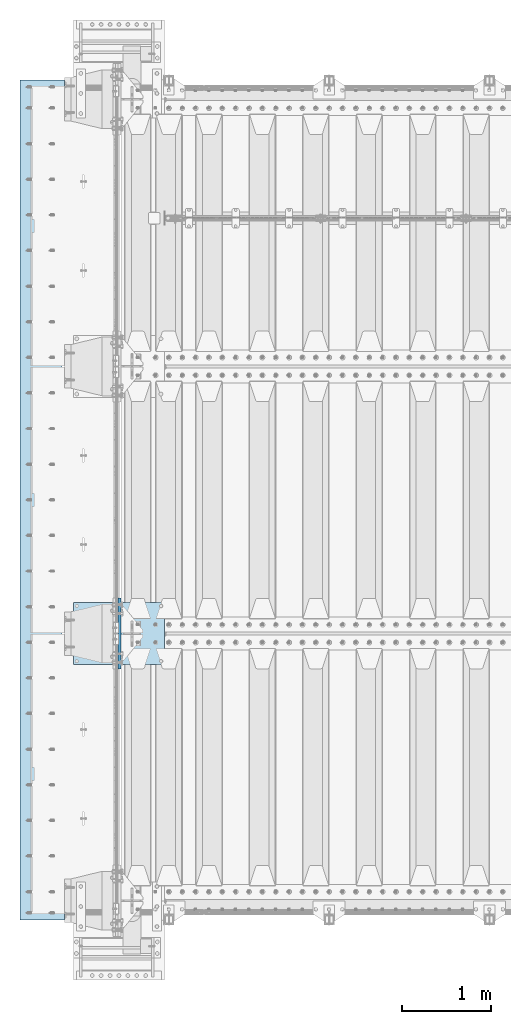
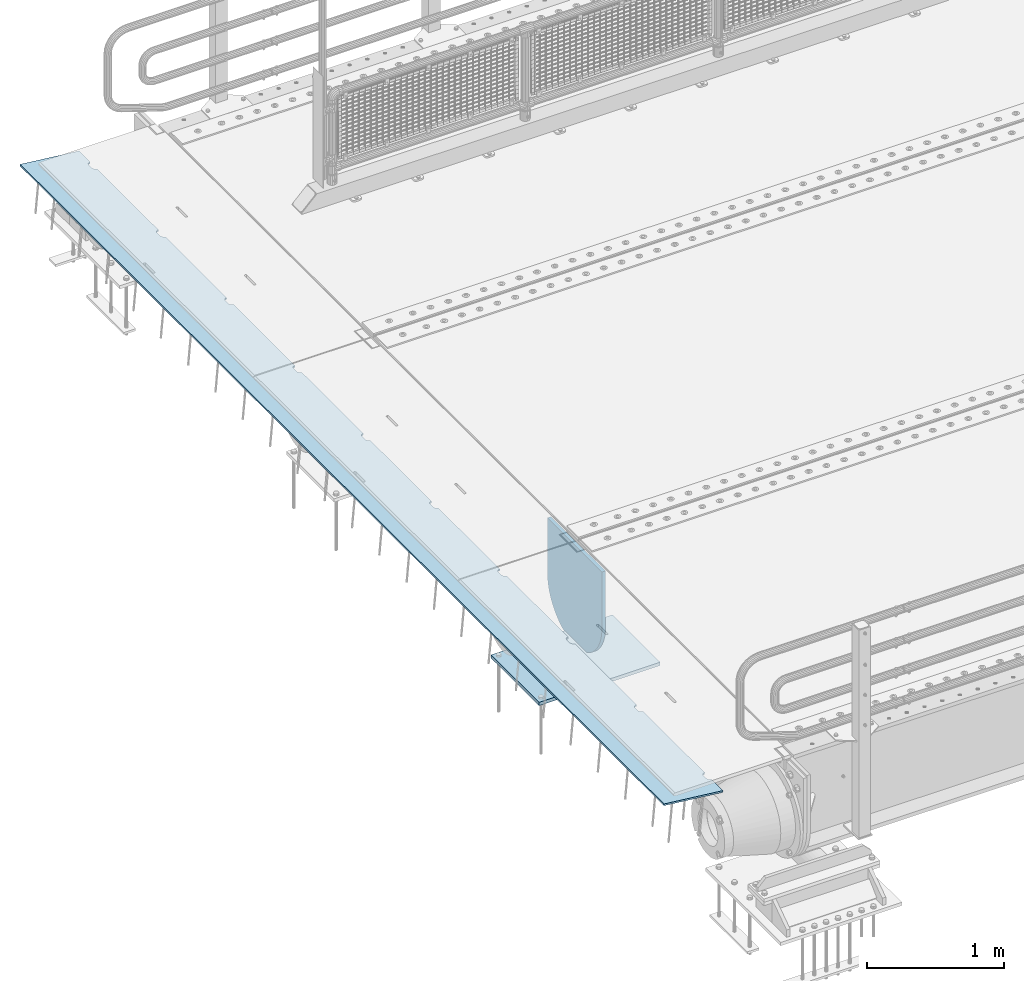
# One storey, part 209 of 270: 3 plates.
"""IFC2X3 building model written with IfcOpenShell, lengths in millimetres."""

from ifc_helpers import new_model, si_unit, frame, origin_with_axes, place, context, subcontext, project, spatial, faceted_brep, material, type_object, element, save


model = new_model("IFC2X3")

# Units and contexts
model_context = context("Model", 3, precision=1e-05, world=origin_with_axes())
body_context = subcontext(model_context, "Body", "Model", "MODEL_VIEW")
ifc_project = project(units=[si_unit("LENGTHUNIT", "METRE", prefix="MILLI"), si_unit("AREAUNIT", "SQUARE_METRE"), si_unit("VOLUMEUNIT", "CUBIC_METRE"), si_unit("MASSUNIT", "GRAM", prefix="KILO"), si_unit("TIMEUNIT", "SECOND"), si_unit("PLANEANGLEUNIT", "RADIAN"), si_unit("SOLIDANGLEUNIT", "STERADIAN"), si_unit("THERMODYNAMICTEMPERATUREUNIT", "DEGREE_CELSIUS"), si_unit("LUMINOUSINTENSITYUNIT", "LUMEN")], contexts=[model_context])

# Site, building, storey
site_placement = place(None, origin_with_axes())
site = spatial("IfcSite", under=ifc_project, at=site_placement, CompositionType="ELEMENT")
building_placement = place(site_placement, origin_with_axes())
building = spatial("IfcBuilding", under=site, at=building_placement, Name="Standard", CompositionType="ELEMENT")
storey_placement = place(building_placement, origin_with_axes())
storey = spatial("IfcBuildingStorey", under=building, at=storey_placement, Name="Undefined", CompositionType="ELEMENT", Elevation=0.0)

# Plates
ifc_material = material(Name="STEEL/S355N")
plate_type_1 = type_object("IfcPlateType", PredefinedType="NOTDEFINED")
plate_1_placement = place(storey_placement, frame((-523.999999999993, -20650.0, -1053.0), z_axis=(1.0, 0.0, 0.0), x_axis=(0.0, -1.0, 0.0)))
element("IfcPlate", 1, at=plate_1_placement, inside=storey, type_object=plate_type_1, material=ifc_material, context=body_context, shape_type="Brep", body=[
    faceted_brep([(0.0, -15.0, 0.0), (2.93249286187347e-06, -15.0, 1025.0), (2.93249286187347e-06, 15.0, 1025.0), (0.0, 15.0, 0.0), (700.0, -15.0, 1025.0), (700.0, 15.0, 1025.0), (700.0, -15.0, -6.3664629124105e-12), (700.0, 15.0, -6.3664629124105e-12)], [[[0, 1, 2, 3]], [[1, 4, 5, 2]], [[4, 6, 7, 5]], [[6, 0, 3, 7]], [[5, 7, 3, 2]], [[6, 4, 1, 0]]]),
])
plate_type_2 = type_object("IfcPlateType", PredefinedType="NOTDEFINED")
plate_2_placement = place(storey_placement, frame((-4.99999999999636, -21400.0, -20.0), z_axis=(0.0, 1.0, 0.0), x_axis=(0.0, 0.0, -1.0)))
element("IfcPlate", 2, at=plate_2_placement, inside=storey, type_object=plate_type_2, material=ifc_material, context=body_context, shape_type="Brep", body=[
    faceted_brep([(855.0, -15.0, 572.963114671544), (855.0, 15.0, 572.963114671544), (849.182410261294, 15.0, 585.889268817533), (849.182410261294, -15.0, 585.889268817533), (824.193546357474, 15.0, 627.225898692486), (824.193546357474, -15.0, 627.225898692486), (794.404299268454, 15.0, 665.249063296342), (794.404299268454, -15.0, 665.249063296342), (760.249063296334, 15.0, 699.404299268463), (760.249063296334, -15.0, 699.404299268463), (722.22589869248, 15.0, 729.193546357488), (722.22589869248, -15.0, 729.193546357488), (680.889268817528, 15.0, 754.18241026131), (680.889268817528, -15.0, 754.18241026131), (636.841954817037, 15.0, 774.006497074191), (636.841954817037, -15.0, 774.006497074191), (590.726265715048, 15.0, 788.376726970451), (590.726265715048, -15.0, 788.376726970451), (543.214672102156, 15.0, 797.083549639254), (543.214672102156, -15.0, 797.083549639254), (495.0, -15.0, 800.000000000029), (495.0, 15.0, 800.0), (494.999999999412, -15.0, 0.0), (494.999999999412, 15.0, 0.0), (543.214672102129, 15.0, 2.91645036080809), (543.214672102129, -15.0, 2.91645036080809), (590.726265715023, 15.0, 11.6232730296069), (590.726265715023, -15.0, 11.6232730296069), (636.841954817014, 15.0, 25.9935029258631), (636.841954817014, -15.0, 25.9935029258631), (680.889268817507, 15.0, 45.8175897387446), (680.889268817507, -15.0, 45.8175897387446), (722.225898692462, 15.0, 70.8064536425663), (722.225898692462, -15.0, 70.8064536425663), (760.249063296318, 15.0, 100.595700731588), (760.249063296318, -15.0, 100.595700731588), (794.404299268441, 15.0, 134.750936703713), (794.404299268441, -15.0, 134.750936703713), (824.193546357463, 15.0, 172.774101307568), (824.193546357463, -15.0, 172.774101307568), (849.182410261284, 15.0, 214.110731182522), (849.182410261284, -15.0, 214.110731182522), (855.0, -15.0, 227.036885328536), (855.0, 15.0, 227.036885328536), (0.0, -15.0, 0.0), (0.0, 15.0, 0.0), (0.0, 15.0, 800.0), (0.0, -15.0, 800.0)], [[[0, 1, 2, 3]], [[3, 2, 4, 5]], [[5, 4, 6, 7]], [[7, 6, 8, 9]], [[9, 8, 10, 11]], [[11, 10, 12, 13]], [[13, 12, 14, 15]], [[15, 14, 16, 17]], [[17, 16, 18, 19]], [[20, 19, 18, 21]], [[22, 23, 24, 25]], [[25, 24, 26, 27]], [[27, 26, 28, 29]], [[29, 28, 30, 31]], [[31, 30, 32, 33]], [[33, 32, 34, 35]], [[35, 34, 36, 37]], [[37, 36, 38, 39]], [[39, 38, 40, 41]], [[42, 41, 40, 43]], [[42, 43, 1, 0]], [[44, 45, 23, 22]], [[16, 14, 12, 10, 8, 6, 4, 2, 1, 43, 40, 38, 36, 34, 32, 30, 28, 26, 24, 23, 45, 46, 21, 18]], [[44, 47, 46, 45]], [[46, 47, 20, 21]], [[47, 44, 22, 25, 27, 29, 31, 33, 35, 37, 39, 41, 42, 0, 3, 5, 7, 9, 11, 13, 15, 17, 19, 20]]]),
])
plate_type_3 = type_object("IfcPlateType", PredefinedType="NOTDEFINED")
plate_3_placement = place(storey_placement, frame((-624.181254970226, -24215.0000000019, -62.5448235046681), z_axis=(-0.99402353270819, -1.00000033824219e-09, 0.109166003967953), x_axis=(0.0, 1.0, 0.0)))
element("IfcPlate", 3, at=plate_3_placement, inside=storey, type_object=plate_type_3, material=ifc_material, context=body_context, shape_type="Brep", body=[
    faceted_brep([(9165.000000001, -7.5, 7.55625608235277e-05), (9165.00000000271, 7.5, -1.22668097901624e-10), (9165.45576741755, 7.50000000000006, 5.20977563143788), (9165.45576741592, -7.5, 5.20977563143788), (9166.80922138939, 7.50000000000006, 10.260934599855), (9166.80922138776, -7.5, 10.260934599855), (9169.01923790418, 7.50000000000006, 15.000330297888), (9169.01923790254, -7.50000000000003, 15.000330297888), (9172.01866672842, 7.50000000000006, 19.283958585503), (9172.01866672679, -7.50000000000003, 19.2839585855029), (9175.71637173509, 7.50000000000009, 22.9816635848007), (9175.71637173346, -7.5, 22.9816635848008), (9180.00000002869, 7.50000000000006, 25.9810924005067), (9180.00000002705, -7.5, 25.9810924005067), (9184.73939573113, 7.50000000000006, 28.1911089058397), (9184.73939572949, -7.50000000000003, 28.1911089058397), (9189.79055470225, 7.50000000000006, 29.5445628676079), (9189.79055470061, -7.5, 29.5445628676079), (9195.00000003271, 7.50000000000006, 30.0003302720633), (9195.00000003107, -7.50000000000003, 30.0003302720631), (9235.00000003271, 7.50000000000006, 30.0003302323023), (9235.00000003107, -7.5, 30.0003302323022), (9240.20944536226, 7.50000000000009, 29.5445628174901), (9240.20944536062, -7.50000000000001, 29.5445628174901), (9245.26060433067, 7.50000000000006, 28.1911088456803), (9245.26060432903, -7.5, 28.1911088456803), (9250.00000002869, 7.50000000000006, 25.9810923309251), (9250.00000002705, -7.50000000000003, 25.981092330925), (9254.28362831629, 7.50000000000009, 22.9816635067032), (9254.28362831465, -7.49999999999999, 22.9816635067032), (9257.98133331556, 7.50000000000006, 19.2839585000545), (9257.98133331393, -7.5, 19.2839585000544), (9260.98076213124, 7.50000000000006, 15.000330206477), (9260.98076212961, -7.50000000000001, 15.0003302064769), (9263.19077863655, 7.50000000000006, 10.2609345040501), (9263.19077863491, -7.50000000000003, 10.2609345040501), (9264.54423259829, 7.50000000000006, 5.20977553294256), (9264.54423259665, -7.50000000000003, 5.20977553294244), (9265.00000000107, -7.50000000000001, 0.000330202481563902), (9265.00000000271, 7.5, -1.24146026792005e-10), (8265.00000000107, -7.5, 0.00033219055490008), (8264.54423259665, -7.49999999999999, 5.20977752101589), (8264.54423259829, 7.50000000000006, 5.20977752101589), (8265.00000000271, 7.50000000000003, -1.10617293103132e-10), (8263.19077863491, -7.49999999999999, 10.2609364921234), (8263.19077863655, 7.50000000000006, 10.2609364921234), (8260.98076212961, -7.50000000000001, 15.0003321945502), (8260.98076213124, 7.50000000000006, 15.0003321945502), (8257.98133331393, -7.5, 19.2839604881278), (8257.98133331556, 7.50000000000006, 19.2839604881278), (8254.28362831465, -7.5, 22.9816654947765), (8254.28362831629, 7.50000000000009, 22.9816654947766), (8250.00000002705, -7.5, 25.9810943189984), (8250.00000002869, 7.50000000000006, 25.9810943189984), (8245.26060432903, -7.50000000000003, 28.1911108337537), (8245.26060433067, 7.50000000000006, 28.1911108337537), (8240.20944536062, -7.49999999999997, 29.5445648055636), (8240.20944536226, 7.50000000000006, 29.5445648055635), (8235.00000003107, -7.50000000000001, 30.0003322203756), (8235.00000003271, 7.50000000000006, 30.0003322203758), (8195.00000003107, -7.5, 30.0003322601366), (8195.00000003271, 7.50000000000006, 30.0003322601366), (8189.79055470061, -7.5, 29.5445648556811), (8189.79055470225, 7.50000000000006, 29.5445648556811), (8184.73939572949, -7.49999999999999, 28.191110893913), (8184.73939573113, 7.50000000000006, 28.191110893913), (8180.00000002705, -7.5, 25.9810943885799), (8180.00000002869, 7.50000000000006, 25.9810943885799), (8175.71637173346, -7.5, 22.9816655728739), (8175.71637173509, 7.50000000000003, 22.9816655728739), (8172.01866672679, -7.49999999999997, 19.2839605735762), (8172.01866672842, 7.50000000000006, 19.2839605735761), (8169.01923790254, -7.49999999999997, 15.0003322859613), (8169.01923790418, 7.50000000000006, 15.0003322859613), (8166.80922138776, -7.5, 10.2609365879282), (8166.80922138939, 7.50000000000006, 10.2609365879282), (8165.45576741592, -7.50000000000003, 5.20977761951121), (8165.45576741755, 7.50000000000006, 5.2097776195111), (8165.00000000105, -7.49999999999999, 0.000195259053725749), (8165.00000000271, 7.5, -1.09366737888195e-10), (7265.00000000107, -7.49999999999999, 0.000334178628349946), (7265.00000000271, 7.5, -9.72022462519817e-11), (7264.54423259665, -7.50000000000003, 5.20977950908923), (7264.54423259829, 7.50000000000006, 5.20977950908923), (7263.19077863491, -7.50000000000001, 10.2609384801967), (7263.19077863655, 7.50000000000006, 10.2609384801968), (7260.98076212961, -7.50000000000001, 15.0003341826236), (7260.98076213124, 7.50000000000006, 15.0003341826236), (7257.98133331392, -7.50000000000003, 19.2839624762011), (7257.98133331557, 7.50000000000006, 19.2839624762012), (7254.28362831465, -7.50000000000004, 22.98166748285), (7254.28362831629, 7.50000000000006, 22.98166748285), (7250.00000002706, -7.50000000000003, 25.9810963070718), (7250.00000002869, 7.50000000000006, 25.9810963070718), (7245.26060432903, -7.50000000000003, 28.1911128218271), (7245.26060433067, 7.50000000000009, 28.191112821827), (7240.20944536063, -7.50000000000006, 29.5445667936369), (7240.20944536226, 7.50000000000006, 29.5445667936369), (7235.00000003107, -7.50000000000004, 30.000334208449), (7235.00000003271, 7.50000000000006, 30.000334208449), (7195.00000003107, -7.50000000000003, 30.0003342482099), (7195.00000003271, 7.50000000000006, 30.0003342482099), (7189.79055470061, -7.50000000000003, 29.5445668437545), (7189.79055470225, 7.50000000000006, 29.5445668437545), (7184.7393957295, -7.50000000000003, 28.1911128819866), (7184.73939573113, 7.50000000000009, 28.1911128819863), (7180.00000002706, -7.50000000000003, 25.9810963766535), (7180.00000002869, 7.50000000000006, 25.9810963766533), (7175.71637173346, -7.50000000000003, 22.9816675609474), (7175.7163717351, 7.50000000000006, 22.9816675609475), (7172.01866672678, -7.50000000000003, 19.2839625616497), (7172.01866672843, 7.50000000000006, 19.2839625616497), (7169.01923790254, -7.50000000000003, 15.0003342740349), (7169.01923790418, 7.50000000000006, 15.0003342740347), (7166.80922138775, -7.50000000000003, 10.2609385760016), (7166.80922138939, 7.50000000000009, 10.2609385760016), (7165.45576741592, -7.50000000000003, 5.20977960758455), (7165.45576741755, 7.50000000000009, 5.20977960758466), (7165.00000000106, -7.49999999999999, 0.000240574238887348), (7165.00000000271, 7.50000000000003, -9.58380041993223e-11), (6265.00000000107, -7.49999999999997, 0.000336166701686125), (6265.00000000271, 7.50000000000003, -8.3787199400831e-11), (6264.54423259665, -7.50000000000003, 5.20978149716257), (6264.54423259829, 7.5, 5.20978149716268), (6263.19077863491, -7.50000000000003, 10.2609404682702), (6263.19077863655, 7.50000000000003, 10.2609404682701), (6260.98076212961, -7.50000000000004, 15.0003361706968), (6260.98076213124, 7.50000000000003, 15.0003361706969), (6257.98133331392, -7.50000000000004, 19.2839644642745), (6257.98133331557, 7.50000000000003, 19.2839644642746), (6254.28362831465, -7.50000000000003, 22.9816694709234), (6254.28362831629, 7.50000000000003, 22.9816694709233), (6250.00000002706, -7.50000000000003, 25.9810982951451), (6250.00000002869, 7.50000000000003, 25.9810982951452), (6245.26060432903, -7.50000000000004, 28.1911148099003), (6245.26060433067, 7.50000000000003, 28.1911148099005), (6240.20944536063, -7.50000000000004, 29.5445687817104), (6240.20944536226, 7.50000000000003, 29.5445687817102), (6235.00000003107, -7.50000000000006, 30.0003361965222), (6235.00000003271, 7.5, 30.0003361965223), (6195.00000003107, -7.50000000000004, 30.0003362362831), (6195.00000003271, 7.50000000000003, 30.0003362362833), (6189.79055470061, -7.50000000000003, 29.5445688318279), (6189.79055470225, 7.50000000000003, 29.5445688318277), (6184.7393957295, -7.50000000000006, 28.1911148700598), (6184.73939573113, 7.5, 28.1911148700598), (6180.00000002706, -7.50000000000003, 25.9810983647266), (6180.00000002869, 7.5, 25.9810983647267), (6175.71637173346, -7.50000000000004, 22.9816695490207), (6175.7163717351, 7.50000000000003, 22.9816695490208), (6172.01866672678, -7.50000000000003, 19.2839645497229), (6172.01866672843, 7.5, 19.2839645497229), (6169.01923790254, -7.50000000000004, 15.0003362621081), (6169.01923790418, 7.50000000000003, 15.0003362621081), (6166.80922138775, -7.50000000000004, 10.260940564075), (6166.80922138939, 7.5, 10.2609405640749), (6165.45576741592, -7.50000000000003, 5.20978159565789), (6165.45576741755, 7.5, 5.20978159565789), (6165.00000000107, -7.49999999999999, 0.000265084087914147), (6165.00000000271, 7.5, -8.25366441858932e-11), (5265.00000000107, -7.5, 0.000338154774908617), (5265.00000000271, 7.5, -7.03721525496803e-11), (5264.54423259665, -7.5, 5.20978348523579), (5264.54423259829, 7.5, 5.20978348523579), (5263.19077863491, -7.50000000000001, 10.2609424563433), (5263.19077863655, 7.5, 10.2609424563434), (5260.98076212961, -7.5, 15.0003381587703), (5260.98076213124, 7.5, 15.0003381587702), (5257.98133331392, -7.50000000000001, 19.2839664523478), (5257.98133331557, 7.5, 19.2839664523477), (5254.28362831465, -7.5, 22.9816714589966), (5254.28362831629, 7.5, 22.9816714589965), (5250.00000002706, -7.5, 25.9811002832184), (5250.00000002869, 7.5, 25.9811002832183), (5245.26060432903, -7.5, 28.1911167979737), (5245.26060433067, 7.5, 28.1911167979736), (5240.20944536063, -7.50000000000003, 29.5445707697836), (5240.20944536226, 7.5, 29.5445707697835), (5235.00000003107, -7.50000000000001, 30.0003381845955), (5235.00000003271, 7.5, 30.0003381845956), (5195.00000003107, -7.5, 30.0003382243565), (5195.00000003271, 7.5, 30.0003382243566), (5189.79055470061, -7.5, 29.5445708199011), (5189.79055470225, 7.5, 29.5445708199012), (5184.7393957295, -7.50000000000001, 28.1911168581331), (5184.73939573113, 7.5, 28.1911168581331), (5180.00000002706, -7.50000000000001, 25.9811003528), (5180.00000002869, 7.5, 25.9811003527999), (5175.71637173346, -7.50000000000001, 22.981671537094), (5175.7163717351, 7.5, 22.981671537094), (5172.01866672678, -7.50000000000003, 19.2839665377962), (5172.01866672843, 7.5, 19.2839665377962), (5169.01923790254, -7.5, 15.0003382501815), (5169.01923790418, 7.5, 15.0003382501812), (5166.80922138775, -7.50000000000003, 10.2609425521482), (5166.80922138939, 7.5, 10.2609425521483), (5165.45576741592, -7.50000000000003, 5.20978358373122), (5165.45576741755, 7.5, 5.20978358373122), (5165.00000000107, -7.5, 0.000280873017459271), (5165.00000000271, 7.5, -6.90079104970209e-11), (4265.00000000107, -7.5, 0.000340142848472169), (4265.00000000271, 7.5, -5.69571056985296e-11), (4264.54423259665, -7.5, 5.20978547330935), (4264.54423259829, 7.50000000000003, 5.20978547330935), (4263.19077863491, -7.49999999999999, 10.2609444444169), (4263.19077863655, 7.5, 10.2609444444169), (4260.98076212961, -7.5, 15.0003401468435), (4260.98076213124, 7.5, 15.0003401468437), (4257.98133331392, -7.49999999999997, 19.2839684404213), (4257.98133331557, 7.5, 19.2839684404213), (4254.28362831465, -7.49999999999999, 22.9816734470701), (4254.28362831629, 7.50000000000006, 22.98167344707), (4250.00000002706, -7.5, 25.9811022712919), (4250.00000002869, 7.50000000000003, 25.9811022712919), (4245.26060432903, -7.49999999999997, 28.1911187860471), (4245.26060433067, 7.50000000000003, 28.1911187860471), (4240.20944536063, -7.49999999999999, 29.5445727578569), (4240.20944536226, 7.50000000000003, 29.5445727578569), (4235.00000003107, -7.5, 30.000340172669), (4235.00000003271, 7.5, 30.000340172669), (4195.00000003107, -7.5, 30.0003402124299), (4195.00000003271, 7.5, 30.0003402124299), (4189.79055470061, -7.49999999999999, 29.5445728079745), (4189.79055470225, 7.50000000000006, 29.5445728079744), (4184.7393957295, -7.5, 28.1911188462065), (4184.73939573113, 7.50000000000003, 28.1911188462065), (4180.00000002706, -7.50000000000001, 25.9811023408732), (4180.00000002869, 7.5, 25.9811023408733), (4175.71637173346, -7.5, 22.9816735251673), (4175.7163717351, 7.50000000000003, 22.9816735251674), (4172.01866672678, -7.49999999999999, 19.2839685258697), (4172.01866672843, 7.50000000000003, 19.2839685258696), (4169.01923790254, -7.49999999999997, 15.0003402382549), (4169.01923790418, 7.5, 15.0003402382548), (4166.80922138775, -7.49999999999999, 10.2609445402217), (4166.80922138939, 7.50000000000003, 10.2609445402215), (4165.45576741592, -7.49999999999999, 5.20978557180456), (4165.45576741755, 7.5, 5.20978557180456), (4165.00000000107, -7.49999999999999, 0.000292184783234006), (4165.00000000271, 7.5, -5.57065504835919e-11), (3265.00000000107, -7.49999999999999, 0.000342130921580974), (3265.00000000271, 7.50000000000003, -4.36557456851006e-11), (3264.54423259665, -7.5, 5.20978746138246), (3264.54423259829, 7.49999999999994, 5.20978746138258), (3263.19077863491, -7.5, 10.2609464324901), (3263.19077863655, 7.49999999999997, 10.2609464324901), (3260.98076212961, -7.5, 15.0003421349168), (3260.98076213124, 7.49999999999997, 15.0003421349169), (3257.98133331392, -7.50000000000003, 19.2839704284945), (3257.98133331557, 7.49999999999994, 19.2839704284945), (3254.28362831465, -7.50000000000003, 22.9816754351434), (3254.28362831629, 7.49999999999997, 22.9816754351433), (3250.00000002706, -7.5, 25.9811042593651), (3250.00000002869, 7.49999999999994, 25.9811042593651), (3245.26060432903, -7.5, 28.1911207741204), (3245.26060433067, 7.49999999999997, 28.1911207741204), (3240.20944536063, -7.5, 29.5445747459303), (3240.20944536226, 7.5, 29.5445747459304), (3235.00000003107, -7.50000000000001, 30.0003421607422), (3235.00000003271, 7.49999999999997, 30.0003421607423), (3195.00000003107, -7.50000000000003, 30.0003422005032), (3195.00000003271, 7.49999999999994, 30.0003422005033), (3189.79055470061, -7.50000000000003, 29.5445747960479), (3189.79055470225, 7.5, 29.5445747960479), (3184.7393957295, -7.5, 28.1911208342798), (3184.73939573113, 7.5, 28.1911208342798), (3180.00000002706, -7.5, 25.9811043289467), (3180.00000002869, 7.49999999999994, 25.9811043289467), (3175.71637173346, -7.5, 22.9816755132408), (3175.7163717351, 7.49999999999997, 22.9816755132408), (3172.01866672678, -7.5, 19.2839705139429), (3172.01866672843, 7.49999999999997, 19.283970513943), (3169.01923790254, -7.5, 15.0003422263281), (3169.01923790418, 7.49999999999997, 15.0003422263281), (3166.80922138775, -7.5, 10.2609465282949), (3166.80922138939, 7.49999999999997, 10.2609465282949), (3165.45576741592, -7.5, 5.20978755987778), (3165.45576741755, 7.49999999999997, 5.2097875598779), (3165.00000000107, -7.5, 0.000300893983080641), (3165.00000000271, 7.5, -4.24051904701628e-11), (2265.00000000107, -7.49999999999999, 0.00034411899503084), (2265.00000000271, 7.5, -3.02406988339499e-11), (2264.54423259665, -7.50000000000003, 5.20978944945591), (2264.54423259829, 7.5, 5.20978944945591), (2263.19077863491, -7.5, 10.2609484205635), (2263.19077863655, 7.5, 10.2609484205634), (2260.98076212961, -7.50000000000003, 15.0003441229902), (2260.98076213124, 7.5, 15.0003441229902), (2257.98133331392, -7.5, 19.2839724165678), (2257.98133331557, 7.5, 19.2839724165677), (2254.28362831465, -7.50000000000003, 22.9816774232165), (2254.28362831629, 7.5, 22.9816774232166), (2250.00000002706, -7.50000000000003, 25.9811062474383), (2250.00000002869, 7.5, 25.9811062474383), (2245.26060432903, -7.50000000000001, 28.1911227621936), (2245.26060433067, 7.5, 28.1911227621937), (2240.20944536063, -7.50000000000001, 29.5445767340036), (2240.20944536226, 7.5, 29.5445767340035), (2235.00000003107, -7.50000000000003, 30.0003441488155), (2235.00000003271, 7.5, 30.0003441488157), (2195.00000003107, -7.5, 30.0003441885765), (2195.00000003271, 7.5, 30.0003441885766), (2189.79055470061, -7.49999999999999, 29.5445767841211), (2189.79055470225, 7.5, 29.5445767841211), (2184.7393957295, -7.50000000000003, 28.191122822353), (2184.73939573113, 7.5, 28.1911228223531), (2180.00000002706, -7.50000000000001, 25.9811063170199), (2180.00000002869, 7.5, 25.9811063170199), (2175.71637173346, -7.50000000000001, 22.9816775013139), (2175.7163717351, 7.5, 22.9816775013139), (2172.01866672678, -7.50000000000001, 19.2839725020162), (2172.01866672843, 7.50000000000003, 19.2839725020161), (2169.01923790254, -7.50000000000001, 15.0003442144015), (2169.01923790418, 7.5, 15.0003442144016), (2166.80922138775, -7.50000000000001, 10.2609485163682), (2166.80922138939, 7.5, 10.2609485163682), (2165.45576741592, -7.5, 5.20978954795123), (2165.45576741755, 7.50000000000003, 5.20978954795112), (2165.00000000107, -7.5, 0.000307956857113822), (2165.00000000271, 7.5, -2.89901436190121e-11), (1265.00000000107, -7.5, 0.000346107068367019), (1265.00000000271, 7.5, -1.69393388205208e-11), (1264.54423259665, -7.50000000000003, 5.20979143752925), (1264.54423259829, 7.5, 5.20979143752925), (1263.19077863491, -7.50000000000003, 10.2609504086367), (1263.19077863655, 7.5, 10.2609504086369), (1260.98076212961, -7.5, 15.0003461110637), (1260.98076213124, 7.5, 15.0003461110636), (1257.98133331392, -7.50000000000003, 19.2839744046412), (1257.98133331557, 7.5, 19.2839744046413), (1254.28362831465, -7.49999999999999, 22.9816794112901), (1254.28362831629, 7.5, 22.9816794112901), (1250.00000002706, -7.5, 25.9811082355119), (1250.00000002869, 7.5, 25.9811082355118), (1245.26060432903, -7.50000000000003, 28.1911247502671), (1245.26060433067, 7.5, 28.191124750267), (1240.20944536063, -7.5, 29.5445787220769), (1240.20944536226, 7.5, 29.5445787220771), (1235.00000003107, -7.50000000000003, 30.000346136889), (1235.00000003271, 7.5, 30.000346136889), (1195.00000003107, -7.50000000000001, 30.0003461766499), (1195.00000003271, 7.5, 30.0003461766499), (1189.79055470061, -7.50000000000003, 29.5445787721945), (1189.79055470225, 7.5, 29.5445787721945), (1184.7393957295, -7.5, 28.1911248104265), (1184.73939573113, 7.5, 28.1911248104263), (1180.00000002706, -7.50000000000003, 25.9811083050934), (1180.00000002869, 7.5, 25.9811083050932), (1175.71637173346, -7.50000000000003, 22.9816794893873), (1175.7163717351, 7.5, 22.9816794893874), (1172.01866672678, -7.50000000000001, 19.2839744900897), (1172.01866672843, 7.5, 19.2839744900896), (1169.01923790254, -7.50000000000001, 15.0003462024749), (1169.01923790418, 7.5, 15.0003462024748), (1166.80922138775, -7.50000000000003, 10.2609505044416), (1166.80922138939, 7.5, 10.2609505044416), (1165.45576741592, -7.50000000000003, 5.20979153602445), (1165.45576741755, 7.5, 5.20979153602457), (1165.00000000107, -7.5, 0.000313912300271113), (1165.00000000271, 7.5, -1.5688783605583e-11), (265.000000001073, -7.5, 0.000348095141589511), (265.000000002707, 7.5, -3.5242919693701e-12), (264.544232596651, -7.5, 5.20979342560247), (264.544232598288, 7.5, 5.20979342560258), (263.190778634911, -7.5, 10.2609523967102), (263.190778636552, 7.5, 10.26095239671), (260.980762129606, -7.5, 15.0003480991368), (260.980762131243, 7.49999999999997, 15.0003480991369), (257.981333313925, -7.50000000000001, 19.2839763927145), (257.981333315565, 7.5, 19.2839763927146), (254.28362831465, -7.50000000000001, 22.9816813993633), (254.283628316287, 7.5, 22.9816813993633), (250.000000027056, -7.5, 25.981110223585), (250.000000028689, 7.5, 25.9811102235851), (245.260604329033, -7.50000000000001, 28.1911267383402), (245.26060433067, 7.5, 28.1911267383404), (240.209445360626, -7.5, 29.5445807101503), (240.209445362263, 7.5, 29.5445807101503), (235.000000031072, -7.50000000000001, 30.0003481249622), (235.000000032709, 7.5, 30.0003481249623), (195.000000031072, -7.50000000000001, 30.0003481647233), (195.000000032709, 7.5, 30.0003481647233), (189.790554700608, -7.49999999999999, 29.5445807602679), (189.790554702246, 7.5, 29.5445807602678), (184.739395729495, -7.50000000000001, 28.1911267984998), (184.739395731132, 7.5, 28.1911267984998), (180.000000027056, -7.50000000000001, 25.9811102931666), (180.000000028689, 7.5, 25.9811102931667), (175.716371733459, -7.5, 22.9816814774607), (175.716371735096, 7.5, 22.9816814774608), (172.018666726784, -7.5, 19.283976478163), (172.018666728425, 7.5, 19.2839764781629), (169.019237902539, -7.5, 15.000348190548), (169.019237904176, 7.5, 15.0003481905482), (166.809221387754, -7.49999999999999, 10.260952492515), (166.809221389394, 7.49999999999997, 10.2609524925149), (165.455767415915, -7.5, 5.2097935240979), (165.455767417552, 7.5, 5.2097935240979), (165.000000001073, -7.5, -2.1600499167107e-12), (165.000000002707, 7.5, -2.1600499167107e-12), (-7.105427357601e-15, -7.49999999999999, 0.0), (-7.105427357601e-15, 7.5, 0.0), (7.81546987127513e-08, -7.5, 500.00244140625), (7.81546987127513e-08, 7.5, 500.00244140625), (9430.00000000299, -7.49999999999999, 500.002380371094), (9430.00000000299, 7.5, 500.002380371094), (9430.0, -7.5, -1.26306076708715e-10), (9430.0, 7.5, -1.26192389870994e-10)], [[[0, 1, 2, 3]], [[3, 2, 4, 5]], [[5, 4, 6, 7]], [[7, 6, 8, 9]], [[9, 8, 10, 11]], [[11, 10, 12, 13]], [[13, 12, 14, 15]], [[15, 14, 16, 17]], [[17, 16, 18, 19]], [[19, 18, 20, 21]], [[21, 20, 22, 23]], [[23, 22, 24, 25]], [[25, 24, 26, 27]], [[27, 26, 28, 29]], [[29, 28, 30, 31]], [[31, 30, 32, 33]], [[33, 32, 34, 35]], [[35, 34, 36, 37]], [[38, 37, 36, 39]], [[40, 41, 42, 43]], [[44, 45, 42, 41]], [[46, 47, 45, 44]], [[48, 49, 47, 46]], [[50, 51, 49, 48]], [[52, 53, 51, 50]], [[54, 55, 53, 52]], [[56, 57, 55, 54]], [[58, 59, 57, 56]], [[60, 61, 59, 58]], [[62, 63, 61, 60]], [[64, 65, 63, 62]], [[66, 67, 65, 64]], [[68, 69, 67, 66]], [[70, 71, 69, 68]], [[72, 73, 71, 70]], [[74, 75, 73, 72]], [[76, 77, 75, 74]], [[78, 79, 77, 76]], [[80, 81, 79, 78]], [[80, 82, 83, 81]], [[84, 85, 83, 82]], [[86, 87, 85, 84]], [[88, 89, 87, 86]], [[90, 91, 89, 88]], [[92, 93, 91, 90]], [[94, 95, 93, 92]], [[96, 97, 95, 94]], [[98, 99, 97, 96]], [[100, 101, 99, 98]], [[102, 103, 101, 100]], [[104, 105, 103, 102]], [[106, 107, 105, 104]], [[108, 109, 107, 106]], [[110, 111, 109, 108]], [[112, 113, 111, 110]], [[114, 115, 113, 112]], [[116, 117, 115, 114]], [[118, 119, 117, 116]], [[120, 121, 119, 118]], [[120, 122, 123, 121]], [[124, 125, 123, 122]], [[126, 127, 125, 124]], [[128, 129, 127, 126]], [[130, 131, 129, 128]], [[132, 133, 131, 130]], [[134, 135, 133, 132]], [[136, 137, 135, 134]], [[138, 139, 137, 136]], [[140, 141, 139, 138]], [[142, 143, 141, 140]], [[144, 145, 143, 142]], [[146, 147, 145, 144]], [[148, 149, 147, 146]], [[150, 151, 149, 148]], [[152, 153, 151, 150]], [[154, 155, 153, 152]], [[156, 157, 155, 154]], [[158, 159, 157, 156]], [[160, 161, 159, 158]], [[160, 162, 163, 161]], [[164, 165, 163, 162]], [[166, 167, 165, 164]], [[168, 169, 167, 166]], [[170, 171, 169, 168]], [[172, 173, 171, 170]], [[174, 175, 173, 172]], [[176, 177, 175, 174]], [[178, 179, 177, 176]], [[180, 181, 179, 178]], [[182, 183, 181, 180]], [[184, 185, 183, 182]], [[186, 187, 185, 184]], [[188, 189, 187, 186]], [[190, 191, 189, 188]], [[192, 193, 191, 190]], [[194, 195, 193, 192]], [[196, 197, 195, 194]], [[198, 199, 197, 196]], [[200, 201, 199, 198]], [[200, 202, 203, 201]], [[204, 205, 203, 202]], [[206, 207, 205, 204]], [[208, 209, 207, 206]], [[210, 211, 209, 208]], [[212, 213, 211, 210]], [[214, 215, 213, 212]], [[216, 217, 215, 214]], [[218, 219, 217, 216]], [[220, 221, 219, 218]], [[222, 223, 221, 220]], [[224, 225, 223, 222]], [[226, 227, 225, 224]], [[228, 229, 227, 226]], [[230, 231, 229, 228]], [[232, 233, 231, 230]], [[234, 235, 233, 232]], [[236, 237, 235, 234]], [[238, 239, 237, 236]], [[240, 241, 239, 238]], [[240, 242, 243, 241]], [[244, 245, 243, 242]], [[246, 247, 245, 244]], [[248, 249, 247, 246]], [[250, 251, 249, 248]], [[252, 253, 251, 250]], [[254, 255, 253, 252]], [[256, 257, 255, 254]], [[258, 259, 257, 256]], [[260, 261, 259, 258]], [[262, 263, 261, 260]], [[264, 265, 263, 262]], [[266, 267, 265, 264]], [[268, 269, 267, 266]], [[270, 271, 269, 268]], [[272, 273, 271, 270]], [[274, 275, 273, 272]], [[276, 277, 275, 274]], [[278, 279, 277, 276]], [[280, 281, 279, 278]], [[280, 282, 283, 281]], [[284, 285, 283, 282]], [[286, 287, 285, 284]], [[288, 289, 287, 286]], [[290, 291, 289, 288]], [[292, 293, 291, 290]], [[294, 295, 293, 292]], [[296, 297, 295, 294]], [[298, 299, 297, 296]], [[300, 301, 299, 298]], [[302, 303, 301, 300]], [[304, 305, 303, 302]], [[306, 307, 305, 304]], [[308, 309, 307, 306]], [[310, 311, 309, 308]], [[312, 313, 311, 310]], [[314, 315, 313, 312]], [[316, 317, 315, 314]], [[318, 319, 317, 316]], [[320, 321, 319, 318]], [[320, 322, 323, 321]], [[324, 325, 323, 322]], [[326, 327, 325, 324]], [[328, 329, 327, 326]], [[330, 331, 329, 328]], [[332, 333, 331, 330]], [[334, 335, 333, 332]], [[336, 337, 335, 334]], [[338, 339, 337, 336]], [[340, 341, 339, 338]], [[342, 343, 341, 340]], [[344, 345, 343, 342]], [[346, 347, 345, 344]], [[348, 349, 347, 346]], [[350, 351, 349, 348]], [[352, 353, 351, 350]], [[354, 355, 353, 352]], [[356, 357, 355, 354]], [[358, 359, 357, 356]], [[360, 361, 359, 358]], [[360, 362, 363, 361]], [[364, 365, 363, 362]], [[366, 367, 365, 364]], [[368, 369, 367, 366]], [[370, 371, 369, 368]], [[372, 373, 371, 370]], [[374, 375, 373, 372]], [[376, 377, 375, 374]], [[378, 379, 377, 376]], [[380, 381, 379, 378]], [[382, 383, 381, 380]], [[384, 385, 383, 382]], [[386, 387, 385, 384]], [[388, 389, 387, 386]], [[390, 391, 389, 388]], [[392, 393, 391, 390]], [[394, 395, 393, 392]], [[396, 397, 395, 394]], [[398, 399, 397, 396]], [[400, 401, 399, 398]], [[400, 402, 403, 401]], [[402, 404, 405, 403]], [[404, 406, 407, 405]], [[407, 406, 38, 39]], [[34, 32, 30, 28, 26, 24, 22, 20, 18, 16, 14, 12, 10, 8, 6, 4, 2, 1, 43, 42, 45, 47, 49, 51, 53, 55, 57, 59, 61, 63, 65, 67, 69, 71, 73, 75, 77, 79, 81, 83, 85, 87, 89, 91, 93, 95, 97, 99, 101, 103, 105, 107, 109, 111, 113, 115, 117, 119, 121, 123, 125, 127, 129, 131, 133, 135, 137, 139, 141, 143, 145, 147, 149, 151, 153, 155, 157, 159, 161, 163, 165, 167, 169, 171, 173, 175, 177, 179, 181, 183, 185, 187, 189, 191, 193, 195, 197, 199, 201, 203, 205, 207, 209, 211, 213, 215, 217, 219, 221, 223, 225, 227, 229, 231, 233, 235, 237, 239, 241, 243, 245, 247, 249, 251, 253, 255, 257, 259, 261, 263, 265, 267, 269, 271, 273, 275, 277, 279, 281, 283, 285, 287, 289, 291, 293, 295, 297, 299, 301, 303, 305, 307, 309, 311, 313, 315, 317, 319, 321, 323, 325, 327, 329, 331, 333, 335, 337, 339, 341, 343, 345, 347, 349, 351, 353, 355, 357, 359, 361, 363, 365, 367, 369, 371, 373, 375, 377, 379, 381, 383, 385, 387, 389, 391, 393, 395, 397, 399, 401, 403, 405, 407, 39, 36]], [[40, 43, 1, 0]], [[406, 404, 402, 400, 398, 396, 394, 392, 390, 388, 386, 384, 382, 380, 378, 376, 374, 372, 370, 368, 366, 364, 362, 360, 358, 356, 354, 352, 350, 348, 346, 344, 342, 340, 338, 336, 334, 332, 330, 328, 326, 324, 322, 320, 318, 316, 314, 312, 310, 308, 306, 304, 302, 300, 298, 296, 294, 292, 290, 288, 286, 284, 282, 280, 278, 276, 274, 272, 270, 268, 266, 264, 262, 260, 258, 256, 254, 252, 250, 248, 246, 244, 242, 240, 238, 236, 234, 232, 230, 228, 226, 224, 222, 220, 218, 216, 214, 212, 210, 208, 206, 204, 202, 200, 198, 196, 194, 192, 190, 188, 186, 184, 182, 180, 178, 176, 174, 172, 170, 168, 166, 164, 162, 160, 158, 156, 154, 152, 150, 148, 146, 144, 142, 140, 138, 136, 134, 132, 130, 128, 126, 124, 122, 120, 118, 116, 114, 112, 110, 108, 106, 104, 102, 100, 98, 96, 94, 92, 90, 88, 86, 84, 82, 80, 78, 76, 74, 72, 70, 68, 66, 64, 62, 60, 58, 56, 54, 52, 50, 48, 46, 44, 41, 40, 0, 3, 5, 7, 9, 11, 13, 15, 17, 19, 21, 23, 25, 27, 29, 31, 33, 35, 37, 38]]]),
])

save(model, "model.ifc")
